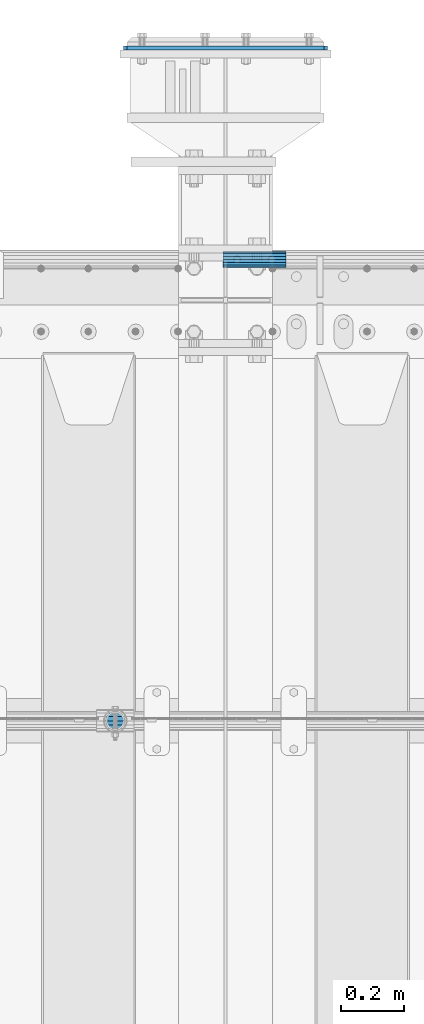
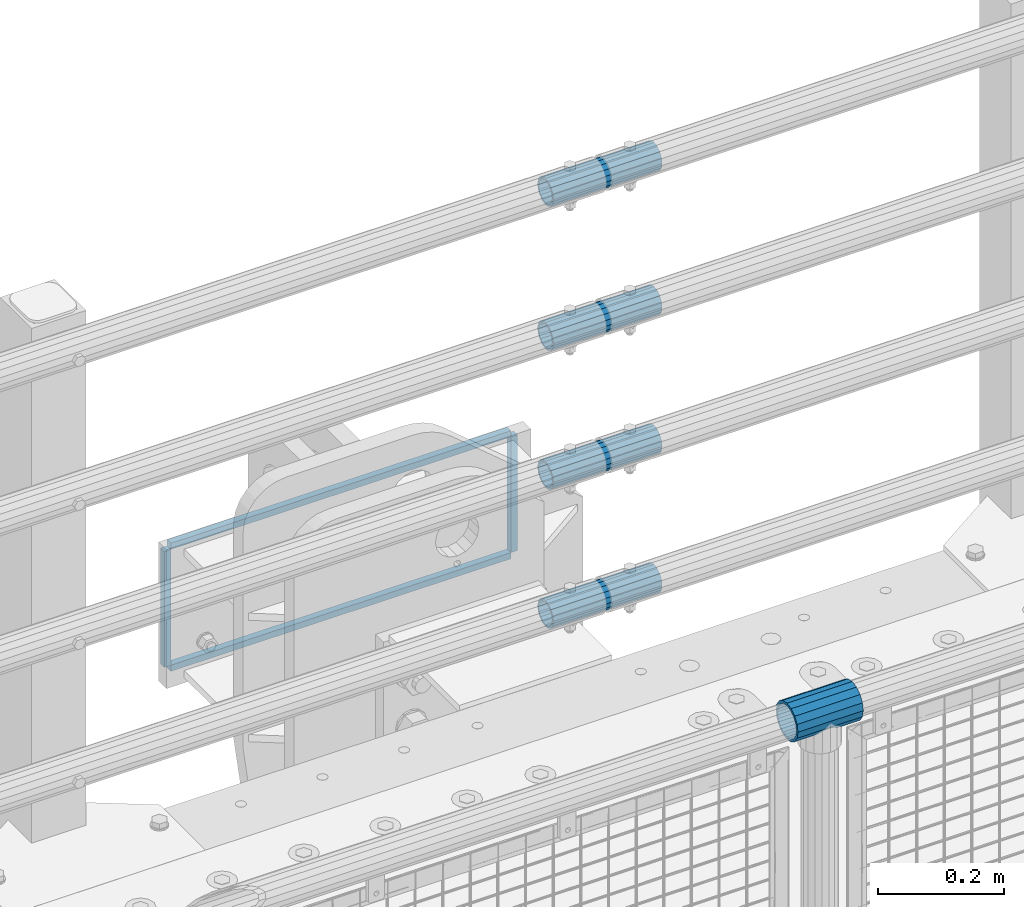
# One storey, part 155 of 242: 9 beams.
"""IFC2X3 building model written with IfcOpenShell, lengths in millimetres."""

from ifc_helpers import new_model, si_unit, frame, origin_with_axes, place, context, subcontext, project, spatial, faceted_brep, material, type_object, element, save


model = new_model("IFC2X3")

# Units and contexts
model_context = context("Model", 3, precision=1e-05, world=origin_with_axes())
body_context = subcontext(model_context, "Body", "Model", "MODEL_VIEW")
ifc_project = project(units=[si_unit("LENGTHUNIT", "METRE", prefix="MILLI"), si_unit("AREAUNIT", "SQUARE_METRE"), si_unit("VOLUMEUNIT", "CUBIC_METRE"), si_unit("MASSUNIT", "GRAM", prefix="KILO"), si_unit("TIMEUNIT", "SECOND"), si_unit("PLANEANGLEUNIT", "RADIAN"), si_unit("SOLIDANGLEUNIT", "STERADIAN"), si_unit("THERMODYNAMICTEMPERATUREUNIT", "DEGREE_CELSIUS"), si_unit("LUMINOUSINTENSITYUNIT", "LUMEN")], contexts=[model_context])

# Site, building, storey
site_placement = place(None, origin_with_axes())
site = spatial("IfcSite", under=ifc_project, at=site_placement, CompositionType="ELEMENT")
building_placement = place(site_placement, origin_with_axes())
building = spatial("IfcBuilding", under=site, at=building_placement, Name="Standard", CompositionType="ELEMENT")
storey_placement = place(building_placement, origin_with_axes())
storey = spatial("IfcBuildingStorey", under=building, at=storey_placement, Name="Undefined", CompositionType="ELEMENT", Elevation=0.0)

# Beams
ifc_material_1 = material(Name="Misc_Undefined")
beam_type_1 = type_object("IfcBeamType", PredefinedType="NOTDEFINED")
beam_1_placement = place(storey_placement, frame((-28825.15, -19335.5, 969.849999999999), z_axis=(0.0, 0.0, 1.0), x_axis=(1.0, 0.0, 0.0)))
element("IfcBeam", 1, at=beam_1_placement, inside=storey, type_object=beam_type_1, material=ifc_material_1, context=body_context, shape_type="Brep", body=[
    faceted_brep([(88.1897438117194, -11.614442172282, -28.0397438117176), (88.1897438117194, -11.614442172282, -32.8397438117175), (86.9623795176813, -13.4513226476338, -32.4743655677718), (81.6106908090114, -21.46069080901, -27.12267685911), (81.6106908090114, -21.46069080901, -21.4606908090117), (76.5310424080017, -24.8548033587067, -24.8548033587072), (71.7644421722835, -28.0397438117179, -20.0882031229829), (71.7644421722835, -28.0397438117179, -11.6144421722805), (60.1500000000015, -30.3499999999985, -16.6306603983671), (60.1500000000015, -30.35, 0.0), (48.5355578277195, -28.0397438117179, -20.0882031229829), (48.5355578277195, -28.0397438117179, -11.6144421722805), (43.7689575920012, -24.8548033587067, -24.8548033587072), (38.6893091909915, -21.46069080901, -27.12267685911), (38.6893091909915, -21.46069080901, -21.4606908090117), (33.3376204823289, -13.4513226476338, -32.4743655677718), (32.1102561882835, -11.614442172282, -32.8397438117175), (32.1102561882835, -11.614442172282, -28.0397438117176), (29.8000000000029, 0.0, -35.15), (29.8000000000029, 0.0, -30.35), (32.1102561882835, 11.614442172282, -32.8397438117171), (32.1102561882835, 11.614442172282, -28.0397438117176), (33.3376204823253, 13.4513226476338, -32.4743655677718), (38.6893091909915, 21.46069080901, -27.12267685911), (38.6893091909915, 21.46069080901, -21.4606908090117), (43.7689575920012, 24.8548033587067, -24.8548033587072), (48.5355578277195, 28.0397438117179, -20.0882031229861), (48.5355578277195, 28.0397438117179, -11.6144421722805), (60.1500000000015, 30.3499999999985, -16.6306603983737), (60.1500000000015, 30.35, 0.0), (71.7644421722835, 28.0397438117179, -20.0882031229861), (71.7644421722835, 28.0397438117179, -11.6144421722805), (76.5310424080017, 24.8548033587067, -24.8548033587072), (81.6106908090114, 21.46069080901, -27.12267685911), (81.6106908090114, 21.46069080901, -21.4606908090117), (86.9623795176667, 13.4513226476338, -32.4743655677718), (88.1897438117194, 11.614442172282, -32.8397438117171), (88.1897438117194, 11.614442172282, -28.0397438117176), (90.5, 0.0, -35.15), (90.5, 0.0, -30.35), (0.0, -21.46069080901, -21.4606908090136), (0.0, -28.0397438117179, -11.6144421722784), (0.0, -11.614442172282, -28.0397438117143), (0.0, 0.0, -30.3499999999985), (0.0, 11.614442172282, -28.0397438117143), (0.0, 21.46069080901, -21.4606908090136), (0.0, 28.0397438117179, -11.6144421722784), (0.0, 30.3499999999985, 0.0), (0.0, 32.4743655677703, -13.4513226476338), (0.0, 35.1500000000015, 0.0), (120.299999999999, 35.1500000000015, 0.0), (120.299999999999, 32.4743655677703, -13.4513226476329), (0.0, 32.4743655677703, 13.4513226476338), (120.299999999999, 32.4743655677703, 13.4513226476329), (0.0, 24.8548033587067, 24.8548033587067), (120.299999999999, 24.8548033587067, 24.8548033587072), (0.0, 13.4513226476338, 32.4743655677739), (120.299999999999, 13.4513226476338, 32.4743655677718), (0.0, 0.0, 35.1500000000015), (120.299999999999, 0.0, 35.15), (0.0, -13.4513226476338, 32.4743655677739), (120.299999999999, -13.4513226476338, 32.4743655677718), (0.0, -24.8548033587067, 24.8548033587067), (120.299999999999, -24.8548033587067, 24.8548033587072), (0.0, -32.4743655677703, 13.4513226476338), (120.299999999999, -32.4743655677703, 13.4513226476329), (0.0, -35.1500000000015, 0.0), (120.299999999999, -35.1500000000015, 0.0), (0.0, -32.4743655677703, -13.4513226476338), (120.299999999999, -32.4743655677703, -13.4513226476329), (0.0, 24.8548033587067, -24.8548033587067), (0.0, 13.4513226476338, -32.4743655677739), (0.0, 0.0, -35.1500000000015), (0.0, -13.4513226476338, -32.4743655677739), (0.0, -24.8548033587067, -24.8548033587067), (0.0, 28.0397438117179, 11.6144421722784), (0.0, 21.46069080901, 21.4606908090136), (0.0, 11.614442172282, 28.0397438117143), (0.0, 0.0, 30.3499999999985), (0.0, -11.614442172282, 28.0397438117143), (0.0, -21.46069080901, 21.4606908090136), (0.0, -28.0397438117179, 11.6144421722784), (0.0, -30.3499999999985, 0.0), (120.299999999999, -30.3499999999985, 0.0), (120.299999999999, -28.0397438117179, -11.6144421722805), (120.299999999999, -21.46069080901, -21.4606908090117), (120.299999999999, -11.614442172282, -28.0397438117176), (120.299999999999, 0.0, -30.35), (120.299999999999, 21.46069080901, -21.4606908090117), (120.299999999999, 28.0397438117179, -11.6144421722805), (120.299999999999, 11.614442172282, -28.0397438117176), (120.299999999999, 30.3499999999985, 0.0), (120.299999999999, 28.0397438117179, 11.6144421722805), (120.299999999999, 21.46069080901, 21.4606908090117), (120.299999999999, 11.614442172282, 28.0397438117176), (120.299999999999, 0.0, 30.35), (120.299999999999, -11.614442172282, 28.0397438117176), (120.299999999999, -21.46069080901, 21.4606908090117), (120.299999999999, -28.0397438117179, 11.6144421722805), (120.299999999999, -24.8548033587067, -24.8548033587072), (120.299999999999, -13.4513226476338, -32.4743655677718), (120.299999999999, 0.0, -35.15), (120.299999999999, 13.4513226476338, -32.4743655677718), (120.299999999999, 24.8548033587067, -24.8548033587072)], [[[0, 1, 2, 3, 4]], [[4, 3, 5, 6, 7]], [[7, 6, 8, 9]], [[9, 8, 10, 11]], [[11, 10, 12, 13, 14]], [[14, 13, 15, 16, 17]], [[17, 16, 18, 19]], [[19, 18, 20, 21]], [[21, 20, 22, 23, 24]], [[24, 23, 25, 26, 27]], [[27, 26, 28, 29]], [[29, 28, 30, 31]], [[31, 30, 32, 33, 34]], [[34, 33, 35, 36, 37]], [[37, 36, 38, 39]], [[39, 38, 1, 0]], [[40, 41, 11, 14]], [[42, 40, 14, 17]], [[43, 42, 17, 19]], [[44, 43, 19, 21]], [[45, 44, 21, 24]], [[46, 45, 24, 27]], [[47, 46, 27, 29]], [[48, 49, 50, 51]], [[49, 52, 53, 50]], [[52, 54, 55, 53]], [[54, 56, 57, 55]], [[56, 58, 59, 57]], [[58, 60, 61, 59]], [[60, 62, 63, 61]], [[62, 64, 65, 63]], [[64, 66, 67, 65]], [[66, 68, 69, 67]], [[64, 62, 60, 58, 56, 54, 52, 49, 48, 70, 71, 72, 73, 74, 68, 66], [41, 40, 42, 43, 44, 45, 46, 47, 75, 76, 77, 78, 79, 80, 81, 82]], [[41, 82, 9, 11]], [[83, 84, 7, 9]], [[84, 85, 4, 7]], [[85, 86, 0, 4]], [[86, 87, 39, 0]], [[88, 89, 31, 34]], [[90, 88, 34, 37]], [[87, 90, 37, 39]], [[89, 91, 29, 31]], [[75, 47, 29, 91, 92]], [[76, 75, 92, 93]], [[77, 76, 93, 94]], [[78, 77, 94, 95]], [[79, 78, 95, 96]], [[80, 79, 96, 97]], [[81, 80, 97, 98]], [[9, 82, 81, 98, 83]], [[99, 100, 101, 102, 103, 51, 50, 53, 55, 57, 59, 61, 63, 65, 67, 69], [97, 96, 95, 94, 93, 92, 91, 89, 88, 90, 87, 86, 85, 84, 83, 98]], [[35, 102, 101, 38, 36]], [[32, 103, 102, 35, 33]], [[28, 26, 25, 70, 48, 51, 103, 32, 30]], [[22, 71, 70, 25, 23]], [[18, 72, 71, 22, 20]], [[73, 72, 18, 16, 15]], [[74, 73, 15, 13, 12]], [[99, 69, 68, 74, 12, 10, 8, 6, 5]], [[100, 99, 5, 3, 2]], [[101, 100, 2, 1, 38]]]),
])
ifc_material_2 = material()
beam_type_2 = type_object("IfcBeamType", PredefinedType="NOTDEFINED")
beam_2_placement = place(storey_placement, frame((-28423.0024970001, -17870.1499999996, 149.849999999726), z_axis=(0.0, 0.0, 1.0), x_axis=(1.0, 0.0, 0.0)))
element("IfcBeam", 2, at=beam_2_placement, inside=storey, type_object=beam_type_2, material=ifc_material_2, context=body_context, shape_type="Brep", body=[
    faceted_brep([(0.0, -21.9000000000015, 0.0), (0.0, -20.232961761998, 8.38076716879547), (200.0, -20.232961761998, 8.38076716879547), (200.0, -21.9000000000015, 0.0), (0.0, -15.4856385079838, 15.4856385079854), (200.0, -15.4856385079838, 15.4856385079854), (0.0, -8.38076716879368, 20.2329617619972), (200.0, -8.38076716879368, 20.2329617619972), (0.0, 0.0, 21.9), (200.0, 0.0, 21.9), (0.0, 8.38076716879368, 20.2329617619972), (200.0, 8.38076716879368, 20.2329617619972), (0.0, 15.4856385079838, 15.4856385079854), (200.0, 15.4856385079838, 15.4856385079854), (0.0, 20.232961761998, 8.38076716879547), (200.0, 20.232961761998, 8.38076716879547), (0.0, 21.9000000000015, 0.0), (200.0, 21.9000000000015, 0.0), (0.0, 20.232961761998, -8.38076716879547), (200.0, 20.232961761998, -8.38076716879547), (0.0, 15.4856385079838, -15.4856385079854), (200.0, 15.4856385079838, -15.4856385079854), (0.0, 8.38076716879368, -20.2329617619972), (200.0, 8.38076716879368, -20.2329617619972), (0.0, 0.0, -21.9), (200.0, 0.0, -21.9), (0.0, -8.38076716879368, -20.2329617619972), (200.0, -8.38076716879368, -20.2329617619972), (0.0, -15.4856385079838, -15.4856385079854), (200.0, -15.4856385079838, -15.4856385079854), (0.0, -20.232961761998, -8.38076716879547), (200.0, -20.232961761998, -8.38076716879547), (0.0, -25.5, 0.0), (0.0, -23.5589280790373, -9.7584275253098), (200.0, -23.5589280790373, -9.7584275253098), (200.0, -25.5, 0.0), (0.0, -18.0312229202573, -18.031222920257), (200.0, -18.0312229202573, -18.031222920257), (0.0, -9.75842752531025, -23.5589280790378), (200.0, -9.75842752531025, -23.5589280790378), (0.0, 0.0, -25.5), (200.0, 0.0, -25.5), (0.0, 9.75842752531025, -23.5589280790378), (200.0, 9.75842752531025, -23.5589280790378), (0.0, 18.0312229202573, -18.031222920257), (200.0, 18.0312229202573, -18.031222920257), (0.0, 23.5589280790373, -9.7584275253098), (200.0, 23.5589280790373, -9.7584275253098), (0.0, 25.5, 0.0), (200.0, 25.5, 0.0), (0.0, 23.5589280790373, 9.7584275253098), (200.0, 23.5589280790373, 9.7584275253098), (0.0, 18.0312229202573, 18.031222920257), (200.0, 18.0312229202573, 18.031222920257), (0.0, 9.75842752531025, 23.5589280790378), (200.0, 9.75842752531025, 23.5589280790378), (0.0, 0.0, 25.5), (200.0, 0.0, 25.5), (0.0, -9.75842752531025, 23.5589280790378), (200.0, -9.75842752531025, 23.5589280790378), (0.0, -18.0312229202573, 18.031222920257), (200.0, -18.0312229202573, 18.031222920257), (0.0, -23.5589280790373, 9.7584275253098), (200.0, -23.5589280790373, 9.7584275253098)], [[[0, 1, 2, 3]], [[1, 4, 5, 2]], [[4, 6, 7, 5]], [[6, 8, 9, 7]], [[8, 10, 11, 9]], [[10, 12, 13, 11]], [[12, 14, 15, 13]], [[14, 16, 17, 15]], [[16, 18, 19, 17]], [[18, 20, 21, 19]], [[20, 22, 23, 21]], [[22, 24, 25, 23]], [[24, 26, 27, 25]], [[26, 28, 29, 27]], [[28, 30, 31, 29]], [[30, 0, 3, 31]], [[32, 33, 34, 35]], [[33, 36, 37, 34]], [[36, 38, 39, 37]], [[38, 40, 41, 39]], [[40, 42, 43, 41]], [[42, 44, 45, 43]], [[44, 46, 47, 45]], [[46, 48, 49, 47]], [[48, 50, 51, 49]], [[50, 52, 53, 51]], [[52, 54, 55, 53]], [[54, 56, 57, 55]], [[56, 58, 59, 57]], [[58, 60, 61, 59]], [[60, 62, 63, 61]], [[62, 32, 35, 63]], [[37, 39, 41, 43, 45, 47, 49, 51, 53, 55, 57, 59, 61, 63, 35, 34], [5, 7, 9, 11, 13, 15, 17, 19, 21, 23, 25, 27, 29, 31, 3, 2]], [[62, 60, 58, 56, 54, 52, 50, 48, 46, 44, 42, 40, 38, 36, 33, 32], [30, 28, 26, 24, 22, 20, 18, 16, 14, 12, 10, 8, 6, 4, 1, 0]]]),
])
beam_3_placement = place(storey_placement, frame((-28423.0024970001, -17870.1499999996, 420.149999999725), z_axis=(0.0, 0.0, 1.0), x_axis=(1.0, 0.0, 0.0)))
element("IfcBeam", 3, at=beam_3_placement, inside=storey, type_object=beam_type_2, material=ifc_material_2, context=body_context, shape_type="Brep", body=[
    faceted_brep([(0.0, -21.9000000000015, 0.0), (0.0, -20.232961761998, 8.38076716879547), (200.0, -20.232961761998, 8.38076716879547), (200.0, -21.9000000000015, 0.0), (0.0, -15.4856385079838, 15.4856385079854), (200.0, -15.4856385079838, 15.4856385079854), (0.0, -8.38076716879368, 20.2329617619972), (200.0, -8.38076716879368, 20.2329617619972), (0.0, 0.0, 21.9), (200.0, 0.0, 21.9), (0.0, 8.38076716879368, 20.2329617619972), (200.0, 8.38076716879368, 20.2329617619972), (0.0, 15.4856385079838, 15.4856385079854), (200.0, 15.4856385079838, 15.4856385079854), (0.0, 20.232961761998, 8.38076716879547), (200.0, 20.232961761998, 8.38076716879547), (0.0, 21.9000000000015, 0.0), (200.0, 21.9000000000015, 0.0), (0.0, 20.232961761998, -8.38076716879547), (200.0, 20.232961761998, -8.38076716879547), (0.0, 15.4856385079838, -15.4856385079854), (200.0, 15.4856385079838, -15.4856385079854), (0.0, 8.38076716879368, -20.2329617619972), (200.0, 8.38076716879368, -20.2329617619972), (0.0, 0.0, -21.9), (200.0, 0.0, -21.9), (0.0, -8.38076716879368, -20.2329617619972), (200.0, -8.38076716879368, -20.2329617619972), (0.0, -15.4856385079838, -15.4856385079854), (200.0, -15.4856385079838, -15.4856385079854), (0.0, -20.232961761998, -8.38076716879547), (200.0, -20.232961761998, -8.38076716879547), (0.0, -25.5, 0.0), (0.0, -23.5589280790373, -9.7584275253098), (200.0, -23.5589280790373, -9.7584275253098), (200.0, -25.5, 0.0), (0.0, -18.0312229202573, -18.031222920257), (200.0, -18.0312229202573, -18.031222920257), (0.0, -9.75842752531025, -23.5589280790378), (200.0, -9.75842752531025, -23.5589280790378), (0.0, 0.0, -25.5), (200.0, 0.0, -25.5), (0.0, 9.75842752531025, -23.5589280790378), (200.0, 9.75842752531025, -23.5589280790378), (0.0, 18.0312229202573, -18.031222920257), (200.0, 18.0312229202573, -18.031222920257), (0.0, 23.5589280790373, -9.7584275253098), (200.0, 23.5589280790373, -9.7584275253098), (0.0, 25.5, 0.0), (200.0, 25.5, 0.0), (0.0, 23.5589280790373, 9.7584275253098), (200.0, 23.5589280790373, 9.7584275253098), (0.0, 18.0312229202573, 18.031222920257), (200.0, 18.0312229202573, 18.031222920257), (0.0, 9.75842752531025, 23.5589280790378), (200.0, 9.75842752531025, 23.5589280790378), (0.0, 0.0, 25.5), (200.0, 0.0, 25.5), (0.0, -9.75842752531025, 23.5589280790378), (200.0, -9.75842752531025, 23.5589280790378), (0.0, -18.0312229202573, 18.031222920257), (200.0, -18.0312229202573, 18.031222920257), (0.0, -23.5589280790373, 9.7584275253098), (200.0, -23.5589280790373, 9.7584275253098)], [[[0, 1, 2, 3]], [[1, 4, 5, 2]], [[4, 6, 7, 5]], [[6, 8, 9, 7]], [[8, 10, 11, 9]], [[10, 12, 13, 11]], [[12, 14, 15, 13]], [[14, 16, 17, 15]], [[16, 18, 19, 17]], [[18, 20, 21, 19]], [[20, 22, 23, 21]], [[22, 24, 25, 23]], [[24, 26, 27, 25]], [[26, 28, 29, 27]], [[28, 30, 31, 29]], [[30, 0, 3, 31]], [[32, 33, 34, 35]], [[33, 36, 37, 34]], [[36, 38, 39, 37]], [[38, 40, 41, 39]], [[40, 42, 43, 41]], [[42, 44, 45, 43]], [[44, 46, 47, 45]], [[46, 48, 49, 47]], [[48, 50, 51, 49]], [[50, 52, 53, 51]], [[52, 54, 55, 53]], [[54, 56, 57, 55]], [[56, 58, 59, 57]], [[58, 60, 61, 59]], [[60, 62, 63, 61]], [[62, 32, 35, 63]], [[37, 39, 41, 43, 45, 47, 49, 51, 53, 55, 57, 59, 61, 63, 35, 34], [5, 7, 9, 11, 13, 15, 17, 19, 21, 23, 25, 27, 29, 31, 3, 2]], [[62, 60, 58, 56, 54, 52, 50, 48, 46, 44, 42, 40, 38, 36, 33, 32], [30, 28, 26, 24, 22, 20, 18, 16, 14, 12, 10, 8, 6, 4, 1, 0]]]),
])
beam_4_placement = place(storey_placement, frame((-28423.0024970001, -17870.1499999996, 969.849999999726), z_axis=(0.0, 0.0, 1.0), x_axis=(1.0, 0.0, 0.0)))
element("IfcBeam", 4, at=beam_4_placement, inside=storey, type_object=beam_type_2, material=ifc_material_2, context=body_context, shape_type="Brep", body=[
    faceted_brep([(0.0, -21.9000000000015, 0.0), (0.0, -20.232961761998, 8.38076716879547), (200.0, -20.232961761998, 8.38076716879547), (200.0, -21.9000000000015, 0.0), (0.0, -15.4856385079838, 15.4856385079854), (200.0, -15.4856385079838, 15.4856385079854), (0.0, -8.38076716879368, 20.2329617619972), (200.0, -8.38076716879368, 20.2329617619972), (0.0, 0.0, 21.9), (200.0, 0.0, 21.9), (0.0, 8.38076716879368, 20.2329617619972), (200.0, 8.38076716879368, 20.2329617619972), (0.0, 15.4856385079838, 15.4856385079854), (200.0, 15.4856385079838, 15.4856385079854), (0.0, 20.232961761998, 8.38076716879547), (200.0, 20.232961761998, 8.38076716879547), (0.0, 21.9000000000015, 0.0), (200.0, 21.9000000000015, 0.0), (0.0, 20.232961761998, -8.38076716879547), (200.0, 20.232961761998, -8.38076716879547), (0.0, 15.4856385079838, -15.4856385079854), (200.0, 15.4856385079838, -15.4856385079854), (0.0, 8.38076716879368, -20.2329617619972), (200.0, 8.38076716879368, -20.2329617619972), (0.0, 0.0, -21.9), (200.0, 0.0, -21.9), (0.0, -8.38076716879368, -20.2329617619972), (200.0, -8.38076716879368, -20.2329617619972), (0.0, -15.4856385079838, -15.4856385079854), (200.0, -15.4856385079838, -15.4856385079854), (0.0, -20.232961761998, -8.38076716879547), (200.0, -20.232961761998, -8.38076716879547), (0.0, -25.5, 0.0), (0.0, -23.5589280790373, -9.7584275253098), (200.0, -23.5589280790373, -9.7584275253098), (200.0, -25.5, 0.0), (0.0, -18.0312229202573, -18.031222920257), (200.0, -18.0312229202573, -18.031222920257), (0.0, -9.75842752531025, -23.5589280790378), (200.0, -9.75842752531025, -23.5589280790378), (0.0, 0.0, -25.5), (200.0, 0.0, -25.5), (0.0, 9.75842752531025, -23.5589280790378), (200.0, 9.75842752531025, -23.5589280790378), (0.0, 18.0312229202573, -18.031222920257), (200.0, 18.0312229202573, -18.031222920257), (0.0, 23.5589280790373, -9.7584275253098), (200.0, 23.5589280790373, -9.7584275253098), (0.0, 25.5, 0.0), (200.0, 25.5, 0.0), (0.0, 23.5589280790373, 9.7584275253098), (200.0, 23.5589280790373, 9.7584275253098), (0.0, 18.0312229202573, 18.031222920257), (200.0, 18.0312229202573, 18.031222920257), (0.0, 9.75842752531025, 23.5589280790378), (200.0, 9.75842752531025, 23.5589280790378), (0.0, 0.0, 25.5), (200.0, 0.0, 25.5), (0.0, -9.75842752531025, 23.5589280790378), (200.0, -9.75842752531025, 23.5589280790378), (0.0, -18.0312229202573, 18.031222920257), (200.0, -18.0312229202573, 18.031222920257), (0.0, -23.5589280790373, 9.7584275253098), (200.0, -23.5589280790373, 9.7584275253098)], [[[0, 1, 2, 3]], [[1, 4, 5, 2]], [[4, 6, 7, 5]], [[6, 8, 9, 7]], [[8, 10, 11, 9]], [[10, 12, 13, 11]], [[12, 14, 15, 13]], [[14, 16, 17, 15]], [[16, 18, 19, 17]], [[18, 20, 21, 19]], [[20, 22, 23, 21]], [[22, 24, 25, 23]], [[24, 26, 27, 25]], [[26, 28, 29, 27]], [[28, 30, 31, 29]], [[30, 0, 3, 31]], [[32, 33, 34, 35]], [[33, 36, 37, 34]], [[36, 38, 39, 37]], [[38, 40, 41, 39]], [[40, 42, 43, 41]], [[42, 44, 45, 43]], [[44, 46, 47, 45]], [[46, 48, 49, 47]], [[48, 50, 51, 49]], [[50, 52, 53, 51]], [[52, 54, 55, 53]], [[54, 56, 57, 55]], [[56, 58, 59, 57]], [[58, 60, 61, 59]], [[60, 62, 63, 61]], [[62, 32, 35, 63]], [[37, 39, 41, 43, 45, 47, 49, 51, 53, 55, 57, 59, 61, 63, 35, 34], [5, 7, 9, 11, 13, 15, 17, 19, 21, 23, 25, 27, 29, 31, 3, 2]], [[62, 60, 58, 56, 54, 52, 50, 48, 46, 44, 42, 40, 38, 36, 33, 32], [30, 28, 26, 24, 22, 20, 18, 16, 14, 12, 10, 8, 6, 4, 1, 0]]]),
])
beam_5_placement = place(storey_placement, frame((-28423.0024970001, -17870.1499999996, 689.849999999726), z_axis=(0.0, 0.0, 1.0), x_axis=(1.0, 0.0, 0.0)))
element("IfcBeam", 5, at=beam_5_placement, inside=storey, type_object=beam_type_2, material=ifc_material_2, context=body_context, shape_type="Brep", body=[
    faceted_brep([(0.0, -21.9000000000015, 0.0), (0.0, -20.232961761998, 8.38076716879547), (200.0, -20.232961761998, 8.38076716879547), (200.0, -21.9000000000015, 0.0), (0.0, -15.4856385079838, 15.4856385079854), (200.0, -15.4856385079838, 15.4856385079854), (0.0, -8.38076716879368, 20.2329617619972), (200.0, -8.38076716879368, 20.2329617619972), (0.0, 0.0, 21.9), (200.0, 0.0, 21.9), (0.0, 8.38076716879368, 20.2329617619972), (200.0, 8.38076716879368, 20.2329617619972), (0.0, 15.4856385079838, 15.4856385079854), (200.0, 15.4856385079838, 15.4856385079854), (0.0, 20.232961761998, 8.38076716879547), (200.0, 20.232961761998, 8.38076716879547), (0.0, 21.9000000000015, 0.0), (200.0, 21.9000000000015, 0.0), (0.0, 20.232961761998, -8.38076716879547), (200.0, 20.232961761998, -8.38076716879547), (0.0, 15.4856385079838, -15.4856385079854), (200.0, 15.4856385079838, -15.4856385079854), (0.0, 8.38076716879368, -20.2329617619972), (200.0, 8.38076716879368, -20.2329617619972), (0.0, 0.0, -21.9), (200.0, 0.0, -21.9), (0.0, -8.38076716879368, -20.2329617619972), (200.0, -8.38076716879368, -20.2329617619972), (0.0, -15.4856385079838, -15.4856385079854), (200.0, -15.4856385079838, -15.4856385079854), (0.0, -20.232961761998, -8.38076716879547), (200.0, -20.232961761998, -8.38076716879547), (0.0, -25.5, 0.0), (0.0, -23.5589280790373, -9.7584275253098), (200.0, -23.5589280790373, -9.7584275253098), (200.0, -25.5, 0.0), (0.0, -18.0312229202573, -18.031222920257), (200.0, -18.0312229202573, -18.031222920257), (0.0, -9.75842752531025, -23.5589280790378), (200.0, -9.75842752531025, -23.5589280790378), (0.0, 0.0, -25.5), (200.0, 0.0, -25.5), (0.0, 9.75842752531025, -23.5589280790378), (200.0, 9.75842752531025, -23.5589280790378), (0.0, 18.0312229202573, -18.031222920257), (200.0, 18.0312229202573, -18.031222920257), (0.0, 23.5589280790373, -9.7584275253098), (200.0, 23.5589280790373, -9.7584275253098), (0.0, 25.5, 0.0), (200.0, 25.5, 0.0), (0.0, 23.5589280790373, 9.7584275253098), (200.0, 23.5589280790373, 9.7584275253098), (0.0, 18.0312229202573, 18.031222920257), (200.0, 18.0312229202573, 18.031222920257), (0.0, 9.75842752531025, 23.5589280790378), (200.0, 9.75842752531025, 23.5589280790378), (0.0, 0.0, 25.5), (200.0, 0.0, 25.5), (0.0, -9.75842752531025, 23.5589280790378), (200.0, -9.75842752531025, 23.5589280790378), (0.0, -18.0312229202573, 18.031222920257), (200.0, -18.0312229202573, 18.031222920257), (0.0, -23.5589280790373, 9.7584275253098), (200.0, -23.5589280790373, 9.7584275253098)], [[[0, 1, 2, 3]], [[1, 4, 5, 2]], [[4, 6, 7, 5]], [[6, 8, 9, 7]], [[8, 10, 11, 9]], [[10, 12, 13, 11]], [[12, 14, 15, 13]], [[14, 16, 17, 15]], [[16, 18, 19, 17]], [[18, 20, 21, 19]], [[20, 22, 23, 21]], [[22, 24, 25, 23]], [[24, 26, 27, 25]], [[26, 28, 29, 27]], [[28, 30, 31, 29]], [[30, 0, 3, 31]], [[32, 33, 34, 35]], [[33, 36, 37, 34]], [[36, 38, 39, 37]], [[38, 40, 41, 39]], [[40, 42, 43, 41]], [[42, 44, 45, 43]], [[44, 46, 47, 45]], [[46, 48, 49, 47]], [[48, 50, 51, 49]], [[50, 52, 53, 51]], [[52, 54, 55, 53]], [[54, 56, 57, 55]], [[56, 58, 59, 57]], [[58, 60, 61, 59]], [[60, 62, 63, 61]], [[62, 32, 35, 63]], [[37, 39, 41, 43, 45, 47, 49, 51, 53, 55, 57, 59, 61, 63, 35, 34], [5, 7, 9, 11, 13, 15, 17, 19, 21, 23, 25, 27, 29, 31, 3, 2]], [[62, 60, 58, 56, 54, 52, 50, 48, 46, 44, 42, 40, 38, 36, 33, 32], [30, 28, 26, 24, 22, 20, 18, 16, 14, 12, 10, 8, 6, 4, 1, 0]]]),
])
ifc_material_3 = material(Name="STEEL/S355N")
beam_type_3 = type_object("IfcBeamType", PredefinedType="NOTDEFINED")
beam_6_placement = place(storey_placement, frame((-28733.5000000603, -17198.9999999654, -22.5000182219899), z_axis=(-1.0, 0.0, 0.0), x_axis=(0.0, 0.0, -1.0)))
element("IfcBeam", 6, at=beam_6_placement, inside=storey, type_object=beam_type_3, material=ifc_material_3, context=body_context, shape_type="Brep", body=[
    faceted_brep([(0.0, 6.0, -6.0), (0.0, 6.0, 6.0), (225.0, 6.0, 6.0), (225.0, 6.0, -6.0), (0.0, -6.0, 6.0), (225.0, -6.0, 6.0), (0.0, -6.0, -6.0), (225.0, -6.0, -6.0)], [[[0, 1, 2, 3]], [[1, 4, 5, 2]], [[4, 6, 7, 5]], [[6, 0, 3, 7]], [[5, 7, 3, 2]], [[6, 4, 1, 0]]]),
])
beam_7_placement = place(storey_placement, frame((-28727.5000000603, -17198.9999999654, -16.5000182219899), z_axis=(0.0, 0.0, -1.0), x_axis=(1.0, 0.0, 0.0)))
element("IfcBeam", 7, at=beam_7_placement, inside=storey, type_object=beam_type_3, material=ifc_material_3, context=body_context, shape_type="Brep", body=[
    faceted_brep([(0.0, 6.0, -6.0), (0.0, 6.0, 6.0), (625.000000001688, 6.0, 6.0), (625.000000001688, 6.0, -6.0), (0.0, -6.0, 6.0), (625.000000001688, -6.0, 6.0), (0.0, -6.0, -6.0), (625.000000001688, -6.0, -6.0)], [[[0, 1, 2, 3]], [[1, 4, 5, 2]], [[4, 6, 7, 5]], [[6, 0, 3, 7]], [[5, 7, 3, 2]], [[6, 4, 1, 0]]]),
])
beam_8_placement = place(storey_placement, frame((-28096.5000000603, -17198.9999999654, -22.5000182219899), z_axis=(-1.0, 0.0, 0.0), x_axis=(0.0, 0.0, -1.0)))
element("IfcBeam", 8, at=beam_8_placement, inside=storey, type_object=beam_type_3, material=ifc_material_3, context=body_context, shape_type="Brep", body=[
    faceted_brep([(0.0, 6.0, -6.0), (0.0, 6.0, 6.0), (225.0, 6.0, 6.0), (225.0, 6.0, -6.0), (0.0, -6.0, 6.0), (225.0, -6.0, 6.0), (0.0, -6.0, -6.0), (225.0, -6.0, -6.0)], [[[0, 1, 2, 3]], [[1, 4, 5, 2]], [[4, 6, 7, 5]], [[6, 0, 3, 7]], [[5, 7, 3, 2]], [[6, 4, 1, 0]]]),
])
beam_9_placement = place(storey_placement, frame((-28727.5000000603, -17198.9999999654, -253.50001822199), z_axis=(0.0, 0.0, -1.0), x_axis=(1.0, 0.0, 0.0)))
element("IfcBeam", 9, at=beam_9_placement, inside=storey, type_object=beam_type_3, material=ifc_material_3, context=body_context, shape_type="Brep", body=[
    faceted_brep([(0.0, 6.0, -6.0), (0.0, 6.0, 6.0), (625.000000001688, 6.0, 6.0), (625.000000001688, 6.0, -6.0), (0.0, -6.0, 6.0), (625.000000001688, -6.0, 6.0), (0.0, -6.0, -6.0), (625.000000001688, -6.0, -6.0)], [[[0, 1, 2, 3]], [[1, 4, 5, 2]], [[4, 6, 7, 5]], [[6, 0, 3, 7]], [[5, 7, 3, 2]], [[6, 4, 1, 0]]]),
])

save(model, "model.ifc")
